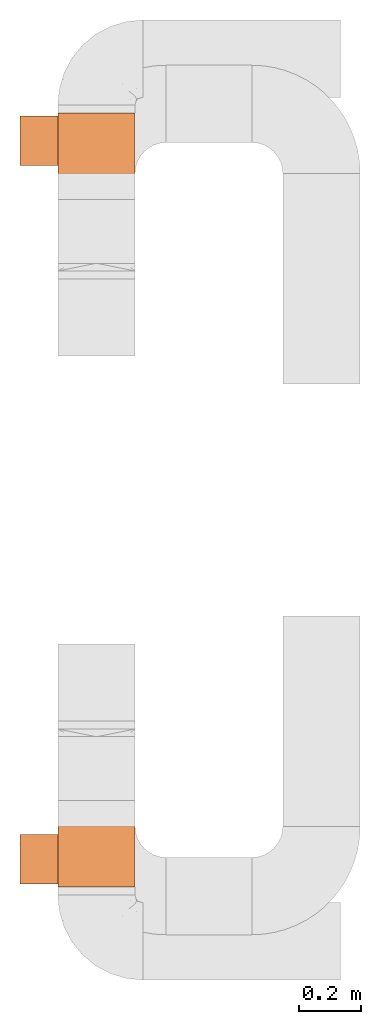
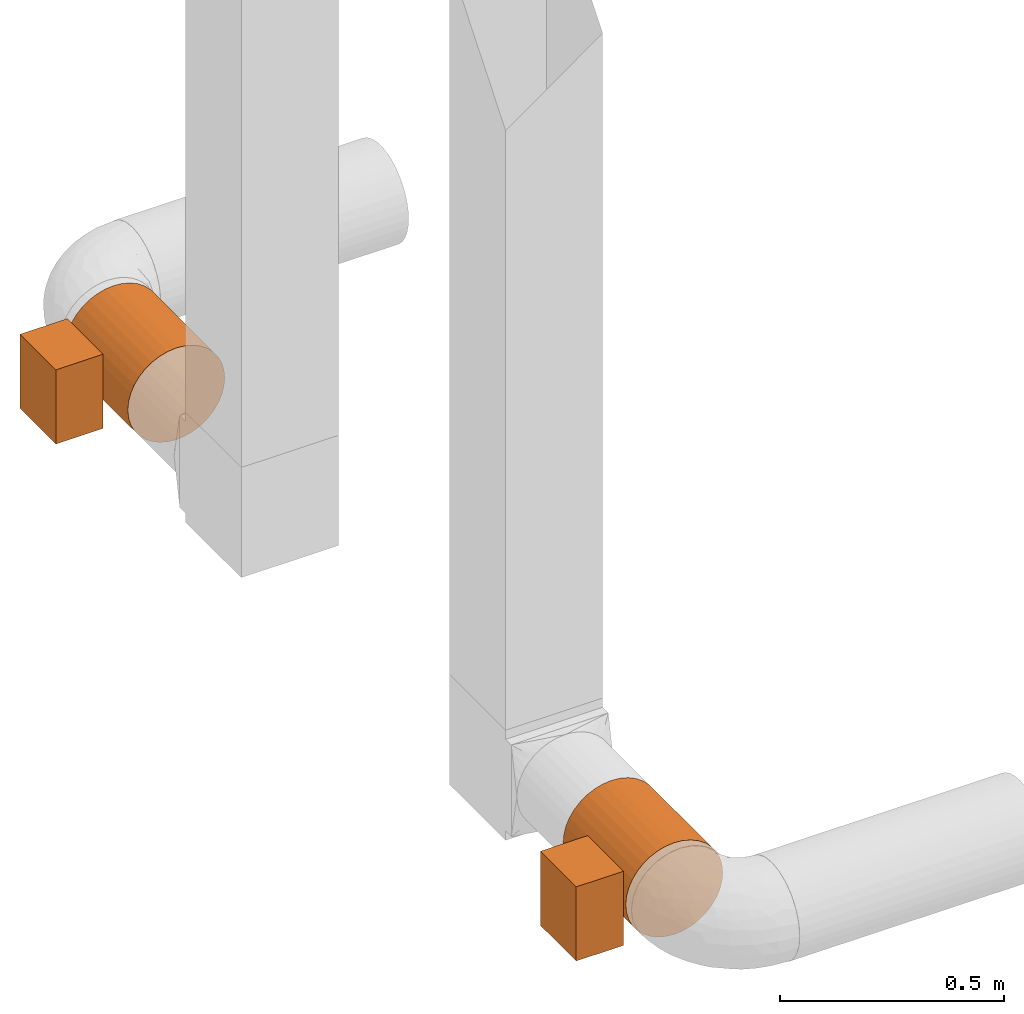
# One storey, part 5 of 5: 2 proxies.
"""IFC2X3 building model written with IfcOpenShell, lengths in millimetres."""

from ifc_helpers import new_model, entity, si_unit, converted_unit, derived_unit, direction, frame, frame_2d, origin, origin_2d_with_axis, place, context, subcontext, project, spatial, rectangle, circle, extrude, source, transform, mapped, type_object, type_shapes, element, save


model = new_model("IFC2X3")

# Units and contexts
model_context = context("Model", 3, precision=0.01, world=origin(), true_north=direction((6.12303176911189e-17, 1.0)))
body_context = subcontext(model_context, "Body", "Model", "MODEL_VIEW")
ifc_project = project(units=[si_unit("LENGTHUNIT", "METRE", prefix="MILLI"), si_unit("AREAUNIT", "SQUARE_METRE"), si_unit("VOLUMEUNIT", "CUBIC_METRE"), converted_unit("PLANEANGLEUNIT", "DEGREE", entity("IfcRatioMeasure", 0.0174532925199433), si_unit("PLANEANGLEUNIT", "RADIAN"), dimensions=[0, 0, 0, 0, 0, 0, 0]), si_unit("MASSUNIT", "GRAM", prefix="KILO"), derived_unit("MASSDENSITYUNIT", [(si_unit("MASSUNIT", "GRAM", prefix="KILO"), 1), (si_unit("LENGTHUNIT", "METRE"), -3)]), si_unit("TIMEUNIT", "SECOND"), si_unit("FREQUENCYUNIT", "HERTZ"), si_unit("THERMODYNAMICTEMPERATUREUNIT", "DEGREE_CELSIUS"), derived_unit("THERMALTRANSMITTANCEUNIT", [(si_unit("MASSUNIT", "GRAM", prefix="KILO"), 1), (si_unit("THERMODYNAMICTEMPERATUREUNIT", "KELVIN"), -1), (si_unit("TIMEUNIT", "SECOND"), -3)]), derived_unit("VOLUMETRICFLOWRATEUNIT", [(si_unit("LENGTHUNIT", "METRE"), 3), (si_unit("TIMEUNIT", "SECOND"), -1)]), si_unit("ELECTRICCURRENTUNIT", "AMPERE"), si_unit("ELECTRICVOLTAGEUNIT", "VOLT"), si_unit("POWERUNIT", "WATT"), si_unit("FORCEUNIT", "NEWTON", prefix="KILO"), si_unit("ILLUMINANCEUNIT", "LUX"), si_unit("LUMINOUSFLUXUNIT", "LUMEN"), si_unit("LUMINOUSINTENSITYUNIT", "CANDELA"), derived_unit("USERDEFINED", [(si_unit("MASSUNIT", "GRAM", prefix="KILO"), -1), (si_unit("LENGTHUNIT", "METRE"), -2), (si_unit("TIMEUNIT", "SECOND"), 3), (si_unit("LUMINOUSFLUXUNIT", "LUMEN"), 1)]), derived_unit("LINEARVELOCITYUNIT", [(si_unit("LENGTHUNIT", "METRE"), 1), (si_unit("TIMEUNIT", "SECOND"), -1)]), si_unit("PRESSUREUNIT", "PASCAL"), derived_unit("USERDEFINED", [(si_unit("LENGTHUNIT", "METRE"), -2), (si_unit("MASSUNIT", "GRAM", prefix="KILO"), 1), (si_unit("TIMEUNIT", "SECOND"), -2)])], contexts=[model_context])

# Site, building, storey
site_placement = place(None, origin())
site = spatial("IfcSite", under=ifc_project, at=site_placement, CompositionType="ELEMENT")
building_placement = place(site_placement, origin())
building = spatial("IfcBuilding", under=site, at=building_placement, CompositionType="ELEMENT")
storey_placement = place(building_placement, frame((0.0, 0.0, 4000.0)))
storey = spatial("IfcBuildingStorey", under=building, at=storey_placement, Name="01 Level", CompositionType="ELEMENT", Elevation=4000.0)

# Proxies
building_element_proxy_type_1 = type_object("IfcBuildingElementProxyType", Name="WH25-250-1", PredefinedType="NOTDEFINED")
shared_shape_1 = source(origin(), body_context, "Body", "SweptSolid", [
    extrude(rectangle(XDim=202.0, YDim=160.0, at=origin_2d_with_axis()), frame((50.0, -16.0, 125.0), z_axis=(0.0, 0.0, 1.0), x_axis=(0.0, -1.0, 0.0)), (0.0, 0.0, 1.0), 122.0),
    extrude(circle(Radius=125.0, at=frame_2d((0.0, -2.01943071804073e-13), x_axis=(1.0, 0.0))), frame((-140.0, 0.0, 0.0), z_axis=(1.0, 0.0, 0.0), x_axis=(0.0, 1.0, 0.0)), (0.0, 0.0, 1.0), 280.0),
])
type_shapes(building_element_proxy_type_1, [shared_shape_1])
proxy_1_placement = place(storey_placement, frame((25195.9632723171, -69942.4616421939, 3510.0), z_axis=(-1.0, 0.0, 0.0), x_axis=(0.0, -1.0, 0.0)))
element("IfcBuildingElementProxy", 1, at=proxy_1_placement, inside=storey, type_object=building_element_proxy_type_1, Name="WH25-0001:WH25-250-1", ObjectType="WH25-0001:WH25-250-1", context=body_context, shape_type="MappedRepresentation", body=[
    mapped(shared_shape_1, transform((0.0, 0.0, 0.0), scale=1.0)),
])
building_element_proxy_type_2 = type_object("IfcBuildingElementProxyType", Name="WH25-250-1", PredefinedType="NOTDEFINED")
shared_shape_2 = source(origin(), body_context, "Body", "SweptSolid", [
    extrude(rectangle(XDim=160.0, YDim=202.0, at=origin_2d_with_axis()), frame((50.0, 16.0, 125.0)), (0.0, 0.0, 1.0), 122.0),
    extrude(circle(Radius=125.0, at=frame_2d((0.0, -1.74187496188444e-13), x_axis=(1.0, 0.0))), frame((-140.0, 0.0, 0.0), z_axis=(1.0, 0.0, 0.0), x_axis=(0.0, -1.0, 0.0)), (0.0, 0.0, 1.0), 280.0),
])
type_shapes(building_element_proxy_type_2, [shared_shape_2])
proxy_2_placement = place(storey_placement, frame((25195.9632723171, -67720.0175280859, 3510.0), z_axis=(-1.0, 0.0, 0.0), x_axis=(0.0, 1.0, 0.0)))
element("IfcBuildingElementProxy", 2, at=proxy_2_placement, inside=storey, type_object=building_element_proxy_type_2, Name="WH25-0001:WH25-250-1", ObjectType="WH25-0001:WH25-250-1", context=body_context, shape_type="MappedRepresentation", body=[
    mapped(shared_shape_2, transform((0.0, 0.0, 0.0), scale=1.0)),
])

save(model, "model.ifc")
